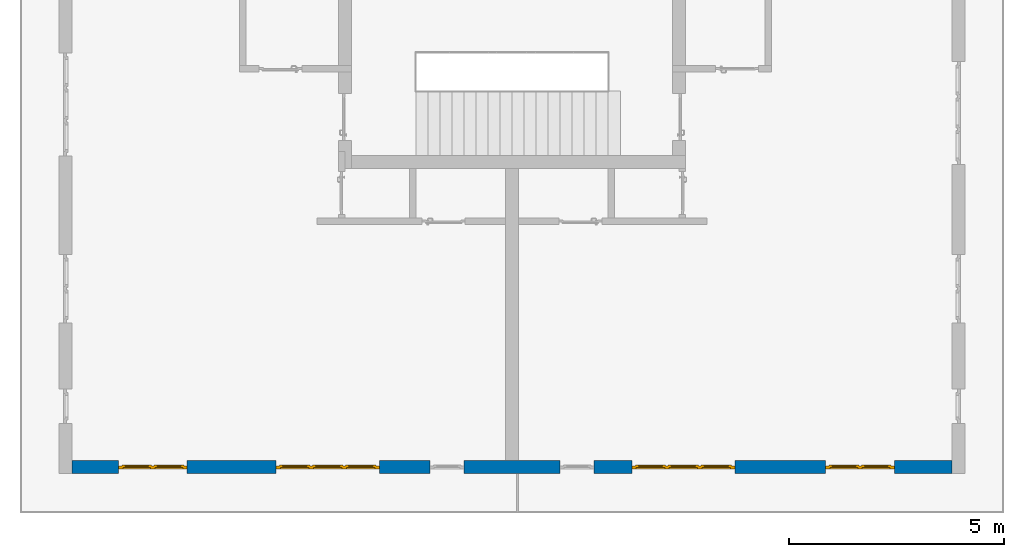
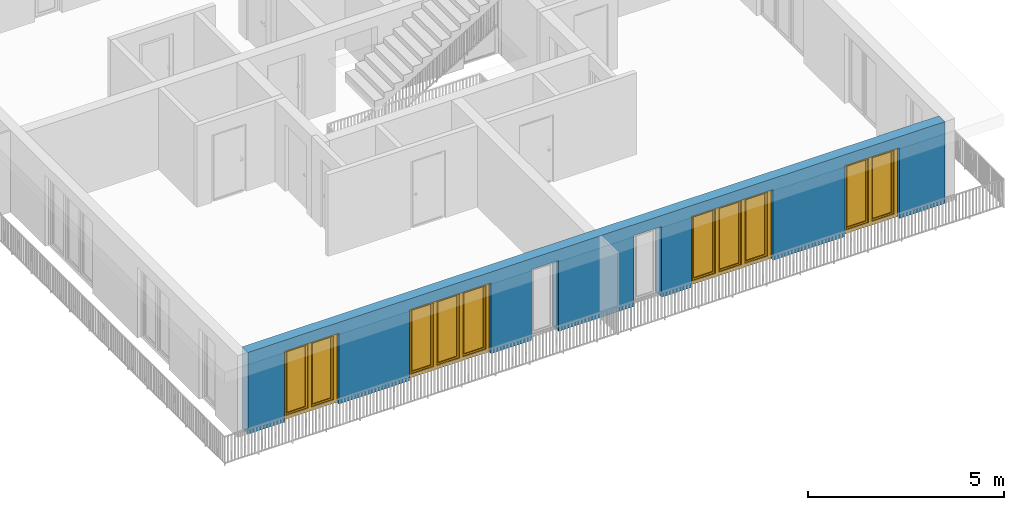
# One storey, part 5 of 48: 4 windows, 1 wall, 6 openings.
"""IFC4 building model written with IfcOpenShell, lengths in metres."""

import ifcopenshell
import ifcopenshell.guid

model = None  # the IFC model being written
_history = None  # IfcOwnerHistory: only IFC2X3 demands one
_inside = {}  # id of a spatial element -> (the spatial element, [elements in it])
_under = {}  # id of a project, library or spatial element -> (it, [spatial elements below it])
_declared = {}  # id of a project -> (the project, [libraries it declares])
_typed = {}  # id of a type object -> (the type object, [elements of that type])
_made_of = {}  # id of a material, layer set ... -> (it, [elements and type objects made of it])


def new_model(schema):
    """Start an empty IFC model of exactly this schema.

    Asked for "IFC4X3", IfcOpenShell would pick the latest addendum, in which some entities
    have other attributes; the version numbers below select the first issue.
    IFC2X3 requires an IfcOwnerHistory on every rooted entity: one is made here for all.
    """
    global model, _history
    if schema == "IFC4X3":
        model = ifcopenshell.file(schema_version=(4, 3, 0, 0))
    else:
        model = ifcopenshell.file(schema=schema)
    _inside.clear()
    _under.clear()
    _declared.clear()
    _typed.clear()
    _made_of.clear()
    _history = None
    if model.schema == "IFC2X3":
        org = make("IfcOrganization", Name="unknown")
        user = make(
            "IfcPersonAndOrganization",
            ThePerson=make("IfcPerson", FamilyName="unknown"),
            TheOrganization=org,
        )
        app = make(
            "IfcApplication",
            ApplicationDeveloper=org,
            Version="unknown",
            ApplicationFullName="unknown",
            ApplicationIdentifier="unknown",
        )
        _history = make(
            "IfcOwnerHistory",
            OwningUser=user,
            OwningApplication=app,
            ChangeAction="ADDED",
            CreationDate=0,
        )
    return model


def make(cls, **values):
    """One entity of the class cls with the attributes given. An attribute that is None is left unset."""
    return model.create_entity(
        cls, **{name: value for name, value in values.items() if value is not None}
    )


def entity(cls, *values):
    """Any entity or typed value of the class cls, its attributes in the order of the schema. None: left unset."""
    e = model.create_entity(cls)
    for i, value in enumerate(values):
        if value is not None:
            e[i] = value
    return e


def rooted(cls, **values):
    """An entity with a GlobalId (a new one), such as an element, a storey or a relation."""
    return make(cls, GlobalId=ifcopenshell.guid.new(), OwnerHistory=_history, **values)


def si_unit(unit_type, name, prefix=None):
    """IfcSIUnit, for example si_unit("LENGTHUNIT", "METRE", prefix="MILLI")."""
    return make("IfcSIUnit", UnitType=unit_type, Prefix=prefix, Name=name)


def converted_unit(unit_type, name, factor, base, dimensions=None, offset=None):
    """IfcConversionBasedUnit, such as the inch: factor (a typed value) times the base unit."""
    return make(
        "IfcConversionBasedUnit"
        if offset is None
        else "IfcConversionBasedUnitWithOffset",
        ConversionOffset=offset,
        Dimensions=None
        if dimensions is None
        else entity("IfcDimensionalExponents", *dimensions),
        UnitType=unit_type,
        Name=name,
        ConversionFactor=make(
            "IfcMeasureWithUnit", ValueComponent=factor, UnitComponent=base
        ),
    )


def derived_unit(unit_type, elements):
    """IfcDerivedUnit: a product of units, each with its exponent."""
    return make(
        "IfcDerivedUnit",
        Elements=[
            make("IfcDerivedUnitElement", Unit=unit, Exponent=power)
            for unit, power in elements
        ],
        UnitType=unit_type,
    )


def assignment(units):
    """IfcUnitAssignment: the units of a project."""
    return None if units is None else make("IfcUnitAssignment", Units=units)


def point(xyz):
    """IfcCartesianPoint."""
    return None if xyz is None else make("IfcCartesianPoint", Coordinates=xyz)


def direction(xyz):
    """IfcDirection."""
    return None if xyz is None else make("IfcDirection", DirectionRatios=xyz)


def frame(location, z_axis=None, x_axis=None):
    """IfcAxis2Placement3D, a coordinate frame: its origin and axes. An axis left out is left unset."""
    return make(
        "IfcAxis2Placement3D",
        Location=point(location),
        Axis=direction(z_axis),
        RefDirection=direction(x_axis),
    )


def origin_with_axes():
    """The frame at (0, 0, 0) with the z axis (0, 0, 1) and the x axis (1, 0, 0) written out."""
    return frame((0.0, 0.0, 0.0), z_axis=(0.0, 0.0, 1.0), x_axis=(1.0, 0.0, 0.0))


def place(relative_to, where):
    """IfcLocalPlacement: puts the frame where relative to a parent placement (None: the world)."""
    return make(
        "IfcLocalPlacement", PlacementRelTo=relative_to, RelativePlacement=where
    )


def context(
    kind, dimensions, precision=None, world=None, true_north=None, identifier=None
):
    """IfcGeometricRepresentationContext, for example the 3D "Model" context."""
    return make(
        "IfcGeometricRepresentationContext",
        ContextIdentifier=identifier,
        ContextType=kind,
        CoordinateSpaceDimension=dimensions,
        Precision=precision,
        WorldCoordinateSystem=world,
        TrueNorth=true_north,
    )


def subcontext(parent, identifier, kind, view, scale=None):
    """IfcGeometricRepresentationSubContext, for example "Body" below "Model"."""
    return make(
        "IfcGeometricRepresentationSubContext",
        ContextIdentifier=identifier,
        ContextType=kind,
        ParentContext=parent,
        TargetScale=scale,
        TargetView=view,
    )


def project(units=None, contexts=None):
    """IfcProject with its units and contexts."""
    return rooted(
        "IfcProject",
        Name="project",
        RepresentationContexts=contexts,
        UnitsInContext=assignment(units),
    )


def spatial(cls, under=None, at=None, **own):
    """A site, building, storey or space (cls), placed at a placement, below another one or the project."""
    s = rooted(cls, ObjectPlacement=at, **own)
    if under is not None:
        _under.setdefault(under.id(), (under, []))[1].append(s)
    return s


def point_list(points):
    """IfcCartesianPointList2D or 3D."""
    cls = (
        "IfcCartesianPointList2D" if len(points[0]) == 2 else "IfcCartesianPointList3D"
    )
    return make(cls, CoordList=points)


def polygons(points, faces, closed=None, point_numbers=None):
    """IfcPolygonalFaceSet: a face is its outer loop, then its inner loops; points numbered from 1."""
    made = []
    for loops in faces:
        if len(loops) == 1:
            made.append(make("IfcIndexedPolygonalFace", CoordIndex=loops[0]))
        else:
            made.append(
                make(
                    "IfcIndexedPolygonalFaceWithVoids",
                    CoordIndex=loops[0],
                    InnerCoordIndices=loops[1:],
                )
            )
    return make(
        "IfcPolygonalFaceSet",
        Coordinates=point_list(points),
        Closed=closed,
        Faces=made,
        PnIndex=point_numbers,
    )


def shape(context_of_items, identifier, shape_type, items):
    """IfcShapeRepresentation: the items that make up one representation, for example the "Body"."""
    return make(
        "IfcShapeRepresentation",
        ContextOfItems=context_of_items,
        RepresentationIdentifier=identifier,
        RepresentationType=shape_type,
        Items=items,
    )


def source(mapping_origin, context_of_items, identifier, shape_type, items):
    """IfcRepresentationMap: a shape defined once, which mapped items show again and again."""
    return make(
        "IfcRepresentationMap",
        MappingOrigin=mapping_origin,
        MappedRepresentation=shape(context_of_items, identifier, shape_type, items),
    )


def transform(
    local_origin,
    x_axis=None,
    y_axis=None,
    z_axis=None,
    scale=None,
    scale2=None,
    scale3=None,
    uniform=True,
):
    """IfcCartesianTransformationOperator3D, or its non-uniform kind. x_axis, y_axis, z_axis: its Axis1, 2, 3."""
    if uniform:
        return make(
            "IfcCartesianTransformationOperator3D",
            Axis1=direction(x_axis),
            Axis2=direction(y_axis),
            LocalOrigin=point(local_origin),
            Scale=scale,
            Axis3=direction(z_axis),
        )
    return make(
        "IfcCartesianTransformationOperator3DnonUniform",
        Axis1=direction(x_axis),
        Axis2=direction(y_axis),
        LocalOrigin=point(local_origin),
        Scale=scale,
        Axis3=direction(z_axis),
        Scale2=scale2,
        Scale3=scale3,
    )


def mapped(mapping_source, mapping_target):
    """IfcMappedItem: shows the shape of a source again, moved by a transform."""
    return make(
        "IfcMappedItem", MappingSource=mapping_source, MappingTarget=mapping_target
    )


def material(Name=None, Category=None):
    """IfcMaterial."""
    return make("IfcMaterial", Name=Name, Category=Category)


def made_of(thing, what):
    """Note that an element or type object is made of a material, layer set ...; save() writes the relation."""
    if what is not None:
        _made_of.setdefault(what.id(), (what, []))[1].append(thing)
    return thing


def type_object(cls, material=None, **own):
    """A type object (cls), such as IfcWallType, which elements share."""
    return made_of(rooted(cls, **own), material)


def element(
    cls,
    number,
    at=None,
    inside=None,
    cuts=None,
    type_object=None,
    material=None,
    context=None,
    identifier="Body",
    shape_type=None,
    held_by="IfcProductDefinitionShape",
    body=None,
    shapes=None,
    **own,
):
    """One element of the class cls, such as IfcWall. Its Tag is "e" and its number.

    at: its placement. inside: the storey or other place that contains it. cuts: it is an
    opening in that element (IfcRelVoidsElement). A single representation is given by context,
    identifier, shape_type and body (its items); several are given by shapes. held_by: the class
    of the entity that holds the representations. save() writes the other relations.
    """
    e = rooted(cls, Tag="e%d" % number, ObjectPlacement=at, **own)
    if body is not None:
        shapes = [shape(context, identifier, shape_type, body)]
    if shapes is not None:
        e.Representation = make(held_by, Representations=shapes)
    if inside is not None:
        _inside.setdefault(inside.id(), (inside, []))[1].append(e)
    if cuts is not None:
        rooted(
            "IfcRelVoidsElement", RelatingBuildingElement=cuts, RelatedOpeningElement=e
        )
    if type_object is not None:
        _typed.setdefault(type_object.id(), (type_object, []))[1].append(e)
    return made_of(e, material)


def fill(opening, filler):
    """IfcRelFillsElement: the door or window that sits in an opening."""
    return rooted(
        "IfcRelFillsElement",
        RelatingOpeningElement=opening,
        RelatedBuildingElement=filler,
    )


def aggregate(whole, parts):
    """IfcRelAggregates: a whole, such as a stair, and the parts it consists of."""
    return rooted("IfcRelAggregates", RelatingObject=whole, RelatedObjects=parts)


def save(model, path):
    """Write the relations noted so far, then the file.

    IfcRelAggregates (storeys below a building ...), IfcRelContainedInSpatialStructure (elements
    in a storey), IfcRelDefinesByType, IfcRelAssociatesMaterial and IfcRelDeclares: one each for
    every whole, place, type object, material and project.
    """
    for whole, parts in _under.values():
        aggregate(whole, parts)
    for where, things in _inside.values():
        rooted(
            "IfcRelContainedInSpatialStructure",
            RelatedElements=things,
            RelatingStructure=where,
        )
    for kind, things in _typed.values():
        rooted("IfcRelDefinesByType", RelatedObjects=things, RelatingType=kind)
    for what, things in _made_of.values():
        rooted("IfcRelAssociatesMaterial", RelatedObjects=things, RelatingMaterial=what)
    for by, libraries in _declared.values():
        rooted("IfcRelDeclares", RelatingContext=by, RelatedDefinitions=libraries)
    model.write(path)


model = new_model("IFC4")

# Units and contexts
model_context = context("Model", 3, precision=1e-05, world=origin_with_axes(), true_north=direction((0.0, 1.0)))
body_context = subcontext(model_context, "Body", "Model", "MODEL_VIEW")
ifc_project = project(units=[si_unit("LENGTHUNIT", "METRE"), si_unit("AREAUNIT", "SQUARE_METRE"), si_unit("VOLUMEUNIT", "CUBIC_METRE"), converted_unit("PLANEANGLEUNIT", "DEGREE", entity("IfcPlaneAngleMeasure", 0.0174532925199), si_unit("PLANEANGLEUNIT", "RADIAN"), dimensions=[0, 0, 0, 0, 0, 0, 0]), converted_unit("TIMEUNIT", "Year", entity("IfcTimeMeasure", 31556926.0), si_unit("TIMEUNIT", "SECOND"), dimensions=[0, 0, 1, 0, 0, 0, 0]), si_unit("MASSUNIT", "GRAM", prefix="KILO"), si_unit("THERMODYNAMICTEMPERATUREUNIT", "DEGREE_CELSIUS"), si_unit("LUMINOUSINTENSITYUNIT", "LUMEN"), si_unit("ENERGYUNIT", "JOULE", prefix="MEGA"), derived_unit("THERMALCONDUCTANCEUNIT", [(si_unit("POWERUNIT", "WATT"), 1), (si_unit("LENGTHUNIT", "METRE"), -1), (si_unit("THERMODYNAMICTEMPERATUREUNIT", "KELVIN"), -1)]), derived_unit("SPECIFICHEATCAPACITYUNIT", [(si_unit("ENERGYUNIT", "JOULE"), 1), (si_unit("MASSUNIT", "GRAM", prefix="KILO"), -1), (si_unit("THERMODYNAMICTEMPERATUREUNIT", "KELVIN"), -1)]), derived_unit("MASSDENSITYUNIT", [(si_unit("MASSUNIT", "GRAM", prefix="KILO"), 1), (si_unit("VOLUMEUNIT", "CUBIC_METRE"), -1)])], contexts=[model_context])

# Site, building, storey
site_placement = place(None, origin_with_axes())
site = spatial("IfcSite", under=ifc_project, at=site_placement, CompositionType="ELEMENT")
building_placement = place(site_placement, origin_with_axes())
building = spatial("IfcBuilding", under=site, at=building_placement, CompositionType="ELEMENT")
storey_placement = place(building_placement, frame((0.0, 0.0, 3.4), z_axis=(0.0, 0.0, 1.0), x_axis=(1.0, 0.0, 0.0)))
storey = spatial("IfcBuildingStorey", under=building, at=storey_placement, Name="1. Geschoss", CompositionType="ELEMENT", Elevation=3.4)

# Wall, openings, windows
ifc_material = material()
wall_type = type_object("IfcWallType", Name="300", PredefinedType="NOTDEFINED")
wall_placement = place(storey_placement, frame((9.3378006196, -9.92881223104, 0.0), z_axis=(0.0, 0.0, 1.0), x_axis=(-1.0, 0.0, 0.0)))
wall = element("IfcWall", 1, at=wall_placement, inside=storey, type_object=wall_type, material=ifc_material, Name="Wand-001", PredefinedType="NOTDEFINED", context=body_context, shape_type="Tessellation", body=[
    polygons([(12.4515538751, -0.3, 2.2), (12.4515538751, -0.3, 0.0), (13.63, -0.3, 0.0), (13.63, -0.3, 2.2), (16.03, -0.3, 2.2), (16.03, -0.3, 0.0), (18.0998837323, -0.3, 0.0), (18.0998837323, -0.3, 2.2), (19.6998837323, -0.3, 2.2), (19.6998837323, -0.3, 0.0), (20.78, -0.3, 0.0), (20.78, -0.3, 2.54), (0.3, -0.3, 2.54), (0.3, -0.3, 0.0), (1.6378225413, -0.3, 0.0), (1.6378225413, -0.3, 2.2), (3.2378225413, -0.3, 2.2), (3.2378225413, -0.3, 0.0), (5.35, -0.3, 0.0), (5.35, -0.3, 2.2), (7.75, -0.3, 2.2), (7.75, -0.3, 0.0), (8.62617854928, -0.3, 0.0), (8.62617854928, -0.3, 2.2), (9.42617854928, -0.3, 2.2), (9.42617854928, -0.3, 0.0), (11.6515538751, -0.3, 0.0), (11.6515538751, -0.3, 2.2), (12.4515538751, -0.1, 0.0), (12.4515538751, 0.0, 2.2), (12.4515538751, 0.0, 0.0), (13.63, 0.0, 0.0), (13.63, 0.0, 2.2), (16.03, 0.0, 2.2), (16.03, 0.0, 0.0), (18.0998837323, 0.0, 0.0), (18.0998837323, 0.0, 2.2), (19.6998837323, 0.0, 2.2), (19.6998837323, 0.0, 0.0), (20.78, 0.0, 0.0), (20.78, 0.0, 2.54), (0.3, 0.0, 2.54), (0.3, 0.0, 0.0), (1.6378225413, 0.0, 0.0), (1.6378225413, 0.0, 2.2), (3.2378225413, 0.0, 2.2), (3.2378225413, 0.0, 0.0), (5.35, 0.0, 0.0), (5.35, 0.0, 2.2), (7.75, 0.0, 2.2), (7.75, 0.0, 0.0), (8.62617854928, 0.0, 0.0), (8.62617854928, 0.0, 2.2), (9.42617854928, 0.0, 2.2), (9.42617854928, 0.0, 0.0), (11.6515538751, -0.1, 0.0), (11.6515538751, 0.0, 0.0), (11.6515538751, 0.0, 2.2)], [[[1, 2, 3, 4, 5, 6, 7, 8, 9, 10, 11, 12, 13, 14, 15, 16, 17, 18, 19, 20, 21, 22, 23, 24, 25, 26, 27, 28]], [[29, 2, 1, 30, 31]], [[2, 29, 31, 32, 3]], [[32, 33, 4, 3]], [[33, 34, 5, 4]], [[34, 35, 6, 5]], [[36, 7, 6, 35]], [[36, 37, 8, 7]], [[37, 38, 9, 8]], [[38, 39, 10, 9]], [[40, 11, 10, 39]], [[40, 41, 12, 11]], [[41, 42, 13, 12]], [[14, 13, 42, 43]], [[15, 14, 43, 44]], [[16, 15, 44, 45]], [[17, 16, 45, 46]], [[18, 17, 46, 47]], [[19, 18, 47, 48]], [[20, 19, 48, 49]], [[21, 20, 49, 50]], [[22, 21, 50, 51]], [[51, 52, 23, 22]], [[52, 53, 24, 23]], [[53, 54, 25, 24]], [[54, 55, 26, 25]], [[56, 27, 26, 55, 57]], [[28, 27, 56, 57, 58]], [[1, 28, 58, 30]], [[32, 31, 30, 58, 57, 55, 54, 53, 52, 51, 50, 49, 48, 47, 46, 45, 44, 43, 42, 41, 40, 39, 38, 37, 36, 35, 34, 33]]], closed=True),
])
opening_1_placement = place(wall_placement, frame((18.8998837323, 0.0, 0.0), z_axis=(0.0, 0.0, 1.0), x_axis=(1.0, 0.0, 0.0)))
opening_1 = element("IfcOpeningElement", 2, at=opening_1_placement, cuts=wall, Name="Fenster-001", context=body_context, identifier="Reference", shape_type="Tessellation", body=[
    polygons([(-0.8, -0.1, 0.0), (-0.8, -0.1, 2.2), (-0.8, 0.001, 2.2), (-0.8, 0.001, 0.0), (-0.8, -0.301, 0.0), (-0.8, -0.301, 2.2), (0.8, -0.1, 2.2), (0.8, 0.001, 2.2), (0.8, -0.301, 2.2), (0.8, 0.001, 0.0), (0.8, -0.1, 0.0), (0.8, -0.301, 0.0)], [[[1, 2, 3, 4]], [[2, 1, 5, 6]], [[7, 8, 3, 2, 6, 9]], [[8, 10, 4, 3]], [[1, 4, 10, 11, 12, 5]], [[6, 5, 12, 9]], [[7, 11, 10, 8]], [[11, 7, 9, 12]]], closed=True),
])
opening_2_placement = place(wall_placement, frame((2.4378225413, 0.0, 0.0), z_axis=(0.0, 0.0, 1.0), x_axis=(1.0, 0.0, 0.0)))
opening_2 = element("IfcOpeningElement", 3, at=opening_2_placement, cuts=wall, Name="Fenster-002", context=body_context, identifier="Reference", shape_type="Tessellation", body=[
    polygons([(-0.8, -0.1, 0.0), (-0.8, -0.1, 2.2), (-0.8, 0.000999999999999, 2.2), (-0.8, 0.000999999999999, 0.0), (-0.8, -0.301, 0.0), (-0.8, -0.301, 2.2), (0.8, -0.1, 2.2), (0.8, 0.000999999999999, 2.2), (0.8, -0.301, 2.2), (0.8, 0.000999999999999, 0.0), (0.8, -0.1, 0.0), (0.8, -0.301, 0.0)], [[[1, 2, 3, 4]], [[2, 1, 5, 6]], [[7, 8, 3, 2, 6, 9]], [[8, 10, 4, 3]], [[1, 4, 10, 11, 12, 5]], [[6, 5, 12, 9]], [[7, 11, 10, 8]], [[11, 7, 9, 12]]], closed=True),
])
opening_3_placement = place(wall_placement, frame((14.83, 0.0, 0.0), z_axis=(0.0, 0.0, 1.0), x_axis=(1.0, 0.0, 0.0)))
opening_3 = element("IfcOpeningElement", 4, at=opening_3_placement, cuts=wall, Name="Fenster-002", context=body_context, identifier="Reference", shape_type="Tessellation", body=[
    polygons([(-1.2, -0.1, 0.0), (-1.2, -0.1, 2.2), (-1.2, 0.001, 2.2), (-1.2, 0.001, 0.0), (-1.2, -0.301, 0.0), (-1.2, -0.301, 2.2), (1.2, -0.1, 2.2), (1.2, 0.001, 2.2), (1.2, -0.301, 2.2), (1.2, 0.001, 0.0), (1.2, -0.1, 0.0), (1.2, -0.301, 0.0)], [[[1, 2, 3, 4]], [[2, 1, 5, 6]], [[7, 8, 3, 2, 6, 9]], [[8, 10, 4, 3]], [[1, 4, 10, 11, 12, 5]], [[6, 5, 12, 9]], [[7, 11, 10, 8]], [[11, 7, 9, 12]]], closed=True),
])
opening_4_placement = place(wall_placement, frame((6.55, 0.0, 0.0), z_axis=(0.0, 0.0, 1.0), x_axis=(1.0, 0.0, 0.0)))
opening_4 = element("IfcOpeningElement", 5, at=opening_4_placement, cuts=wall, Name="Fenster-003", context=body_context, identifier="Reference", shape_type="Tessellation", body=[
    polygons([(-1.2, -0.1, 0.0), (-1.2, -0.1, 2.2), (-1.2, 0.000999999999999, 2.2), (-1.2, 0.000999999999999, 0.0), (-1.2, -0.301, 0.0), (-1.2, -0.301, 2.2), (1.2, -0.1, 2.2), (1.2, 0.001, 2.2), (1.2, -0.301, 2.2), (1.2, 0.001, 0.0), (1.2, -0.1, 0.0), (1.2, -0.301, 0.0)], [[[1, 2, 3, 4]], [[2, 1, 5, 6]], [[7, 8, 3, 2, 6, 9]], [[8, 10, 4, 3]], [[1, 4, 10, 11, 12, 5]], [[6, 5, 12, 9]], [[7, 11, 10, 8]], [[11, 7, 9, 12]]], closed=True),
])
opening_5_placement = place(wall_placement, frame((9.02617854928, 0.0, 0.0), z_axis=(0.0, 0.0, 1.0), x_axis=(1.0, 0.0, 0.0)))
element("IfcOpeningElement", 6, at=opening_5_placement, cuts=wall, Name="Fenster-003", context=body_context, identifier="Reference", shape_type="Tessellation", body=[
    polygons([(-0.4, -0.1, 0.0), (-0.4, -0.1, 2.2), (-0.4, 0.001, 2.2), (-0.4, 0.001, 0.0), (-0.4, -0.301, 0.0), (-0.4, -0.301, 2.2), (0.4, -0.1, 2.2), (0.4, 0.001, 2.2), (0.4, -0.301, 2.2), (0.4, 0.001, 0.0), (0.4, -0.1, 0.0), (0.4, -0.301, 0.0)], [[[1, 2, 3, 4]], [[2, 1, 5, 6]], [[7, 8, 3, 2, 6, 9]], [[8, 10, 4, 3]], [[1, 4, 10, 11, 12, 5]], [[6, 5, 12, 9]], [[7, 11, 10, 8]], [[11, 7, 9, 12]]], closed=True),
])
opening_6_placement = place(wall_placement, frame((12.0515538751, 0.0, 0.0), z_axis=(0.0, 0.0, 1.0), x_axis=(1.0, 0.0, 0.0)))
element("IfcOpeningElement", 7, at=opening_6_placement, cuts=wall, Name="Fenster-003", context=body_context, identifier="Reference", shape_type="Tessellation", body=[
    polygons([(-0.4, -0.1, 0.0), (-0.4, -0.1, 2.2), (-0.4, 0.001, 2.2), (-0.4, 0.001, 0.0), (-0.4, -0.301, 0.0), (-0.4, -0.301, 2.2), (0.4, -0.1, 2.2), (0.4, 0.001, 2.2), (0.4, -0.301, 2.2), (0.4, 0.001, 0.0), (0.4, -0.1, 0.0), (0.4, -0.301, 0.0)], [[[1, 2, 3, 4]], [[2, 1, 5, 6]], [[7, 8, 3, 2, 6, 9]], [[8, 10, 4, 3]], [[1, 4, 10, 11, 12, 5]], [[6, 5, 12, 9]], [[7, 11, 10, 8]], [[11, 7, 9, 12]]], closed=True),
])
window_type_1 = type_object("IfcWindowType", Name="2-1+1 26", PartitioningType="DOUBLE_PANEL_VERTICAL", PredefinedType="WINDOW")
shared_shape_1 = source(origin_with_axes(), body_context, "Body", "Tessellation", [
    polygons([(-0.8, -0.07, 0.0), (-0.8, 0.0, 0.0), (-0.7, 0.0, 0.1), (-0.7, -0.07, 0.1), (-0.8, -0.07, 2.2), (-0.8, 0.0, 2.2), (-0.7, 0.0, 2.1), (-0.7, -0.07, 2.1)], [[[1, 2, 3, 4]], [[5, 6, 2, 1]], [[2, 6, 7, 3]], [[4, 3, 7, 8]], [[1, 4, 8, 5]], [[8, 7, 6, 5]]], closed=True),
    polygons([(0.8, -0.07, 0.0), (0.8, 0.0, 0.0), (0.8, 0.0, 2.2), (0.8, -0.07, 2.2), (0.7, -0.07, 0.1), (0.7, 0.0, 0.1), (0.7, 0.0, 2.1), (0.7, -0.07, 2.1)], [[[1, 2, 3, 4]], [[5, 6, 2, 1]], [[2, 6, 7, 3]], [[4, 3, 7, 8]], [[1, 4, 8, 5]], [[8, 7, 6, 5]]], closed=True),
    polygons([(-0.8, -0.07, 0.0), (-0.8, 0.0, 0.0), (0.8, 0.0, 0.0), (0.8, -0.07, 0.0), (-0.7, -0.07, 0.1), (-0.7, 0.0, 0.1), (-0.05, 0.0, 0.1), (0.05, 0.0, 0.1), (0.7, 0.0, 0.1), (0.7, -0.07, 0.1), (0.05, -0.07, 0.1), (-0.05, -0.07, 0.1)], [[[1, 2, 3, 4]], [[5, 6, 2, 1]], [[2, 6, 7, 8, 9, 3]], [[4, 3, 9, 10]], [[1, 4, 10, 11, 12, 5]], [[12, 7, 6, 5]], [[11, 8, 7, 12]], [[10, 9, 8, 11]]], closed=True),
    polygons([(-0.8, -0.07, 2.2), (-0.8, 0.0, 2.2), (-0.7, 0.0, 2.1), (-0.7, -0.07, 2.1), (0.8, -0.07, 2.2), (0.8, 0.0, 2.2), (0.7, 0.0, 2.1), (0.05, 0.0, 2.1), (-0.05, 0.0, 2.1), (-0.05, -0.07, 2.1), (0.05, -0.07, 2.1), (0.7, -0.07, 2.1)], [[[1, 2, 3, 4]], [[5, 6, 2, 1]], [[2, 6, 7, 8, 9, 3]], [[4, 3, 9, 10]], [[1, 4, 10, 11, 12, 5]], [[12, 7, 6, 5]], [[11, 8, 7, 12]], [[10, 9, 8, 11]]], closed=True),
    polygons([(-0.05, -0.07, 0.1), (-0.05, 0.0, 0.1), (0.05, 0.0, 0.1), (0.05, -0.07, 0.1), (-0.05, -0.07, 2.1), (-0.05, 0.0, 2.1), (0.05, 0.0, 2.1), (0.05, -0.07, 2.1)], [[[1, 2, 3, 4]], [[5, 6, 2, 1]], [[2, 6, 7, 3]], [[4, 3, 7, 8]], [[1, 4, 8, 5]], [[8, 7, 6, 5]]], closed=True),
    polygons([(-0.72, 0.0, 0.08), (-0.72, 0.03, 0.08), (-0.65, 0.03, 0.15), (-0.65, 0.0, 0.15), (-0.72, 0.0, 2.12), (-0.72, 0.03, 2.12), (-0.65, 0.03, 2.05), (-0.65, 0.0, 2.05)], [[[1, 2, 3, 4]], [[5, 6, 2, 1]], [[2, 6, 7, 3]], [[4, 3, 7, 8]], [[1, 4, 8, 5]], [[8, 7, 6, 5]]], closed=True),
    polygons([(-0.03, 0.0, 0.08), (-0.1, 0.0, 0.15), (-0.1, 0.03, 0.15), (-0.03, 0.03, 0.08), (-0.03, 0.0, 2.12), (-0.1, 0.0, 2.05), (-0.1, 0.03, 2.05), (-0.03, 0.03, 2.12)], [[[1, 2, 3, 4]], [[1, 5, 6, 2]], [[2, 6, 7, 3]], [[4, 3, 7, 8]], [[5, 1, 4, 8]], [[6, 5, 8, 7]]], closed=True),
    polygons([(-0.72, 0.0, 0.08), (-0.72, 0.03, 0.08), (-0.03, 0.03, 0.08), (-0.03, 0.0, 0.08), (-0.65, 0.0, 0.15), (-0.65, 0.03, 0.15), (-0.1, 0.03, 0.15), (-0.1, 0.0, 0.15)], [[[1, 2, 3, 4]], [[5, 6, 2, 1]], [[2, 6, 7, 3]], [[4, 3, 7, 8]], [[1, 4, 8, 5]], [[8, 7, 6, 5]]], closed=True),
    polygons([(-0.72, 0.0, 2.12), (-0.03, 0.0, 2.12), (-0.03, 0.03, 2.12), (-0.72, 0.03, 2.12), (-0.65, 0.0, 2.05), (-0.1, 0.0, 2.05), (-0.1, 0.03, 2.05), (-0.65, 0.03, 2.05)], [[[1, 2, 3, 4]], [[1, 5, 6, 2]], [[2, 6, 7, 3]], [[4, 3, 7, 8]], [[5, 1, 4, 8]], [[6, 5, 8, 7]]], closed=True),
    polygons([(-0.7, -0.03, 0.1), (-0.7, 0.0, 0.1), (-0.65, 0.0, 0.15), (-0.65, -0.03, 0.15), (-0.7, -0.03, 2.1), (-0.7, 0.0, 2.1), (-0.65, 0.0, 2.05), (-0.65, -0.03, 2.05)], [[[1, 2, 3, 4]], [[5, 6, 2, 1]], [[2, 6, 7, 3]], [[4, 3, 7, 8]], [[1, 4, 8, 5]], [[8, 7, 6, 5]]], closed=True),
    polygons([(-0.05, -0.03, 0.1), (-0.1, -0.03, 0.15), (-0.1, 0.0, 0.15), (-0.05, 0.0, 0.1), (-0.05, -0.03, 2.1), (-0.1, -0.03, 2.05), (-0.1, 0.0, 2.05), (-0.05, 0.0, 2.1)], [[[1, 2, 3, 4]], [[1, 5, 6, 2]], [[2, 6, 7, 3]], [[4, 3, 7, 8]], [[5, 1, 4, 8]], [[6, 5, 8, 7]]], closed=True),
    polygons([(-0.7, -0.03, 0.1), (-0.7, 0.0, 0.1), (-0.05, 0.0, 0.1), (-0.05, -0.03, 0.1), (-0.65, -0.03, 0.15), (-0.65, 0.0, 0.15), (-0.1, 0.0, 0.15), (-0.1, -0.03, 0.15)], [[[1, 2, 3, 4]], [[5, 6, 2, 1]], [[2, 6, 7, 3]], [[4, 3, 7, 8]], [[1, 4, 8, 5]], [[8, 7, 6, 5]]], closed=True),
    polygons([(-0.7, -0.03, 2.1), (-0.05, -0.03, 2.1), (-0.05, 0.0, 2.1), (-0.7, 0.0, 2.1), (-0.65, -0.03, 2.05), (-0.1, -0.03, 2.05), (-0.1, 0.0, 2.05), (-0.65, 0.0, 2.05)], [[[1, 2, 3, 4]], [[1, 5, 6, 2]], [[2, 6, 7, 3]], [[4, 3, 7, 8]], [[5, 1, 4, 8]], [[6, 5, 8, 7]]], closed=True),
    polygons([(-0.65, -0.005, 0.15), (-0.65, 0.005, 0.15), (-0.1, 0.005, 0.15), (-0.1, -0.005, 0.15), (-0.65, -0.005, 2.05), (-0.65, 0.005, 2.05), (-0.1, 0.005, 2.05), (-0.1, -0.005, 2.05)], [[[1, 2, 3, 4]], [[5, 6, 2, 1]], [[2, 6, 7, 3]], [[4, 3, 7, 8]], [[1, 4, 8, 5]], [[8, 7, 6, 5]]], closed=True),
    polygons([(0.03, 0.0, 0.08), (0.03, 0.03, 0.08), (0.1, 0.03, 0.15), (0.1, 0.0, 0.15), (0.03, 0.0, 2.12), (0.03, 0.03, 2.12), (0.1, 0.03, 2.05), (0.1, 0.0, 2.05)], [[[1, 2, 3, 4]], [[5, 6, 2, 1]], [[2, 6, 7, 3]], [[4, 3, 7, 8]], [[1, 4, 8, 5]], [[8, 7, 6, 5]]], closed=True),
    polygons([(0.72, 0.0, 0.08), (0.65, 0.0, 0.15), (0.65, 0.03, 0.15), (0.72, 0.03, 0.08), (0.72, 0.0, 2.12), (0.65, 0.0, 2.05), (0.65, 0.03, 2.05), (0.72, 0.03, 2.12)], [[[1, 2, 3, 4]], [[1, 5, 6, 2]], [[2, 6, 7, 3]], [[4, 3, 7, 8]], [[5, 1, 4, 8]], [[6, 5, 8, 7]]], closed=True),
    polygons([(0.03, 0.0, 0.08), (0.03, 0.03, 0.08), (0.72, 0.03, 0.08), (0.72, 0.0, 0.08), (0.1, 0.0, 0.15), (0.1, 0.03, 0.15), (0.65, 0.03, 0.15), (0.65, 0.0, 0.15)], [[[1, 2, 3, 4]], [[5, 6, 2, 1]], [[2, 6, 7, 3]], [[4, 3, 7, 8]], [[1, 4, 8, 5]], [[8, 7, 6, 5]]], closed=True),
    polygons([(0.03, 0.0, 2.12), (0.72, 0.0, 2.12), (0.72, 0.03, 2.12), (0.03, 0.03, 2.12), (0.1, 0.0, 2.05), (0.65, 0.0, 2.05), (0.65, 0.03, 2.05), (0.1, 0.03, 2.05)], [[[1, 2, 3, 4]], [[1, 5, 6, 2]], [[2, 6, 7, 3]], [[4, 3, 7, 8]], [[5, 1, 4, 8]], [[6, 5, 8, 7]]], closed=True),
    polygons([(0.05, -0.03, 0.1), (0.05, 0.0, 0.1), (0.1, 0.0, 0.15), (0.1, -0.03, 0.15), (0.05, -0.03, 2.1), (0.05, 0.0, 2.1), (0.1, 0.0, 2.05), (0.1, -0.03, 2.05)], [[[1, 2, 3, 4]], [[5, 6, 2, 1]], [[2, 6, 7, 3]], [[4, 3, 7, 8]], [[1, 4, 8, 5]], [[8, 7, 6, 5]]], closed=True),
    polygons([(0.7, -0.03, 0.1), (0.65, -0.03, 0.15), (0.65, 0.0, 0.15), (0.7, 0.0, 0.1), (0.7, -0.03, 2.1), (0.65, -0.03, 2.05), (0.65, 0.0, 2.05), (0.7, 0.0, 2.1)], [[[1, 2, 3, 4]], [[1, 5, 6, 2]], [[2, 6, 7, 3]], [[4, 3, 7, 8]], [[5, 1, 4, 8]], [[6, 5, 8, 7]]], closed=True),
    polygons([(0.05, -0.03, 0.1), (0.05, 0.0, 0.1), (0.7, 0.0, 0.1), (0.7, -0.03, 0.1), (0.1, -0.03, 0.15), (0.1, 0.0, 0.15), (0.65, 0.0, 0.15), (0.65, -0.03, 0.15)], [[[1, 2, 3, 4]], [[5, 6, 2, 1]], [[2, 6, 7, 3]], [[4, 3, 7, 8]], [[1, 4, 8, 5]], [[8, 7, 6, 5]]], closed=True),
    polygons([(0.05, -0.03, 2.1), (0.7, -0.03, 2.1), (0.7, 0.0, 2.1), (0.05, 0.0, 2.1), (0.1, -0.03, 2.05), (0.65, -0.03, 2.05), (0.65, 0.0, 2.05), (0.1, 0.0, 2.05)], [[[1, 2, 3, 4]], [[1, 5, 6, 2]], [[2, 6, 7, 3]], [[4, 3, 7, 8]], [[5, 1, 4, 8]], [[6, 5, 8, 7]]], closed=True),
    polygons([(0.1, -0.005, 0.15), (0.1, 0.005, 0.15), (0.65, 0.005, 0.15), (0.65, -0.005, 0.15), (0.1, -0.005, 2.05), (0.1, 0.005, 2.05), (0.65, 0.005, 2.05), (0.65, -0.005, 2.05)], [[[1, 2, 3, 4]], [[5, 6, 2, 1]], [[2, 6, 7, 3]], [[4, 3, 7, 8]], [[1, 4, 8, 5]], [[8, 7, 6, 5]]], closed=True),
])
window_1_placement = place(opening_1_placement, frame((0.8, 0.0, 0.0), z_axis=(0.0, 0.0, 1.0), x_axis=(-1.0, 0.0, 0.0)))
window_1 = element("IfcWindow", 8, at=window_1_placement, inside=storey, type_object=window_type_1, Name="Fenster-001", OverallHeight=2.2, OverallWidth=1.6, PredefinedType="WINDOW", context=body_context, shape_type="MappedRepresentation", body=[
    mapped(shared_shape_1, transform((0.8, 0.17, 0.0))),
])
fill(opening_1, window_1)
window_2_placement = place(opening_2_placement, frame((0.8, 0.0, 0.0), z_axis=(0.0, 0.0, 1.0), x_axis=(-1.0, 0.0, 0.0)))
window_2 = element("IfcWindow", 9, at=window_2_placement, inside=storey, type_object=window_type_1, Name="Fenster-002", OverallHeight=2.2, OverallWidth=1.6, PredefinedType="WINDOW", context=body_context, shape_type="MappedRepresentation", body=[
    mapped(shared_shape_1, transform((0.8, 0.17, 0.0))),
])
fill(opening_2, window_2)
window_type_2 = type_object("IfcWindowType", Name="3-1+1+1 26", PartitioningType="TRIPLE_PANEL_VERTICAL", PredefinedType="WINDOW")
shared_shape_2 = source(origin_with_axes(), body_context, "Body", "Tessellation", [
    polygons([(-1.2, -0.07, 0.0), (-1.2, 0.0, 0.0), (-1.1, 0.0, 0.1), (-1.1, -0.07, 0.1), (-1.2, -0.07, 2.2), (-1.2, 0.0, 2.2), (-1.1, 0.0, 2.1), (-1.1, -0.07, 2.1)], [[[1, 2, 3, 4]], [[5, 6, 2, 1]], [[2, 6, 7, 3]], [[4, 3, 7, 8]], [[1, 4, 8, 5]], [[8, 7, 6, 5]]], closed=True),
    polygons([(1.2, -0.07, 0.0), (1.2, 0.0, 0.0), (1.2, 0.0, 2.2), (1.2, -0.07, 2.2), (1.1, -0.07, 0.1), (1.1, 0.0, 0.1), (1.1, 0.0, 2.1), (1.1, -0.07, 2.1)], [[[1, 2, 3, 4]], [[5, 6, 2, 1]], [[2, 6, 7, 3]], [[4, 3, 7, 8]], [[1, 4, 8, 5]], [[8, 7, 6, 5]]], closed=True),
    polygons([(-1.2, -0.07, 0.0), (-1.2, 0.0, 0.0), (1.2, 0.0, 0.0), (1.2, -0.07, 0.0), (-1.1, -0.07, 0.1), (-1.1, 0.0, 0.1), (-0.433333333333, 0.0, 0.1), (-0.333333333333, 0.0, 0.1), (0.333333333333, 0.0, 0.1), (0.433333333333, 0.0, 0.1), (1.1, 0.0, 0.1), (1.1, -0.07, 0.1), (0.433333333333, -0.07, 0.1), (0.333333333333, -0.07, 0.1), (-0.333333333333, -0.07, 0.1), (-0.433333333333, -0.07, 0.1)], [[[1, 2, 3, 4]], [[5, 6, 2, 1]], [[2, 6, 7, 8, 9, 10, 11, 3]], [[4, 3, 11, 12]], [[1, 4, 12, 13, 14, 15, 16, 5]], [[16, 7, 6, 5]], [[15, 8, 7, 16]], [[14, 9, 8, 15]], [[13, 10, 9, 14]], [[12, 11, 10, 13]]], closed=True),
    polygons([(-1.2, -0.07, 2.2), (-1.2, 0.0, 2.2), (-1.1, 0.0, 2.1), (-1.1, -0.07, 2.1), (1.2, -0.07, 2.2), (1.2, 0.0, 2.2), (1.1, 0.0, 2.1), (0.433333333333, 0.0, 2.1), (0.333333333333, 0.0, 2.1), (-0.333333333333, 0.0, 2.1), (-0.433333333333, 0.0, 2.1), (-0.433333333333, -0.07, 2.1), (-0.333333333333, -0.07, 2.1), (0.333333333333, -0.07, 2.1), (0.433333333333, -0.07, 2.1), (1.1, -0.07, 2.1)], [[[1, 2, 3, 4]], [[5, 6, 2, 1]], [[2, 6, 7, 8, 9, 10, 11, 3]], [[4, 3, 11, 12]], [[1, 4, 12, 13, 14, 15, 16, 5]], [[16, 7, 6, 5]], [[15, 8, 7, 16]], [[14, 9, 8, 15]], [[13, 10, 9, 14]], [[12, 11, 10, 13]]], closed=True),
    polygons([(0.333333333333, -0.07, 0.1), (0.333333333333, 0.0, 0.1), (0.433333333333, 0.0, 0.1), (0.433333333333, -0.07, 0.1), (0.333333333333, -0.07, 2.1), (0.333333333333, 0.0, 2.1), (0.433333333333, 0.0, 2.1), (0.433333333333, -0.07, 2.1)], [[[1, 2, 3, 4]], [[5, 6, 2, 1]], [[2, 6, 7, 3]], [[4, 3, 7, 8]], [[1, 4, 8, 5]], [[8, 7, 6, 5]]], closed=True),
    polygons([(-0.433333333333, -0.07, 0.1), (-0.433333333333, 0.0, 0.1), (-0.333333333333, 0.0, 0.1), (-0.333333333333, -0.07, 0.1), (-0.433333333333, -0.07, 2.1), (-0.433333333333, 0.0, 2.1), (-0.333333333333, 0.0, 2.1), (-0.333333333333, -0.07, 2.1)], [[[1, 2, 3, 4]], [[5, 6, 2, 1]], [[2, 6, 7, 3]], [[4, 3, 7, 8]], [[1, 4, 8, 5]], [[8, 7, 6, 5]]], closed=True),
    polygons([(-1.12, 0.0, 0.08), (-1.12, 0.03, 0.08), (-1.05, 0.03, 0.15), (-1.05, 0.0, 0.15), (-1.12, 0.0, 2.12), (-1.12, 0.03, 2.12), (-1.05, 0.03, 2.05), (-1.05, 0.0, 2.05)], [[[1, 2, 3, 4]], [[5, 6, 2, 1]], [[2, 6, 7, 3]], [[4, 3, 7, 8]], [[1, 4, 8, 5]], [[8, 7, 6, 5]]], closed=True),
    polygons([(-0.413333333333, 0.0, 0.08), (-0.483333333333, 0.0, 0.15), (-0.483333333333, 0.03, 0.15), (-0.413333333333, 0.03, 0.08), (-0.413333333333, 0.0, 2.12), (-0.483333333333, 0.0, 2.05), (-0.483333333333, 0.03, 2.05), (-0.413333333333, 0.03, 2.12)], [[[1, 2, 3, 4]], [[1, 5, 6, 2]], [[2, 6, 7, 3]], [[4, 3, 7, 8]], [[5, 1, 4, 8]], [[6, 5, 8, 7]]], closed=True),
    polygons([(-1.12, 0.0, 0.08), (-1.12, 0.03, 0.08), (-0.413333333333, 0.03, 0.08), (-0.413333333333, 0.0, 0.08), (-1.05, 0.0, 0.15), (-1.05, 0.03, 0.15), (-0.483333333333, 0.03, 0.15), (-0.483333333333, 0.0, 0.15)], [[[1, 2, 3, 4]], [[5, 6, 2, 1]], [[2, 6, 7, 3]], [[4, 3, 7, 8]], [[1, 4, 8, 5]], [[8, 7, 6, 5]]], closed=True),
    polygons([(-1.12, 0.0, 2.12), (-0.413333333333, 0.0, 2.12), (-0.413333333333, 0.03, 2.12), (-1.12, 0.03, 2.12), (-1.05, 0.0, 2.05), (-0.483333333333, 0.0, 2.05), (-0.483333333333, 0.03, 2.05), (-1.05, 0.03, 2.05)], [[[1, 2, 3, 4]], [[1, 5, 6, 2]], [[2, 6, 7, 3]], [[4, 3, 7, 8]], [[5, 1, 4, 8]], [[6, 5, 8, 7]]], closed=True),
    polygons([(-1.1, -0.03, 0.1), (-1.1, 0.0, 0.1), (-1.05, 0.0, 0.15), (-1.05, -0.03, 0.15), (-1.1, -0.03, 2.1), (-1.1, 0.0, 2.1), (-1.05, 0.0, 2.05), (-1.05, -0.03, 2.05)], [[[1, 2, 3, 4]], [[5, 6, 2, 1]], [[2, 6, 7, 3]], [[4, 3, 7, 8]], [[1, 4, 8, 5]], [[8, 7, 6, 5]]], closed=True),
    polygons([(-0.433333333333, -0.03, 0.1), (-0.483333333333, -0.03, 0.15), (-0.483333333333, 0.0, 0.15), (-0.433333333333, 0.0, 0.1), (-0.433333333333, -0.03, 2.1), (-0.483333333333, -0.03, 2.05), (-0.483333333333, 0.0, 2.05), (-0.433333333333, 0.0, 2.1)], [[[1, 2, 3, 4]], [[1, 5, 6, 2]], [[2, 6, 7, 3]], [[4, 3, 7, 8]], [[5, 1, 4, 8]], [[6, 5, 8, 7]]], closed=True),
    polygons([(-1.1, -0.03, 0.1), (-1.1, 0.0, 0.1), (-0.433333333333, 0.0, 0.1), (-0.433333333333, -0.03, 0.1), (-1.05, -0.03, 0.15), (-1.05, 0.0, 0.15), (-0.483333333333, 0.0, 0.15), (-0.483333333333, -0.03, 0.15)], [[[1, 2, 3, 4]], [[5, 6, 2, 1]], [[2, 6, 7, 3]], [[4, 3, 7, 8]], [[1, 4, 8, 5]], [[8, 7, 6, 5]]], closed=True),
    polygons([(-1.1, -0.03, 2.1), (-0.433333333333, -0.03, 2.1), (-0.433333333333, 0.0, 2.1), (-1.1, 0.0, 2.1), (-1.05, -0.03, 2.05), (-0.483333333333, -0.03, 2.05), (-0.483333333333, 0.0, 2.05), (-1.05, 0.0, 2.05)], [[[1, 2, 3, 4]], [[1, 5, 6, 2]], [[2, 6, 7, 3]], [[4, 3, 7, 8]], [[5, 1, 4, 8]], [[6, 5, 8, 7]]], closed=True),
    polygons([(-1.05, -0.005, 0.15), (-1.05, 0.005, 0.15), (-0.483333333333, 0.005, 0.15), (-0.483333333333, -0.005, 0.15), (-1.05, -0.005, 2.05), (-1.05, 0.005, 2.05), (-0.483333333333, 0.005, 2.05), (-0.483333333333, -0.005, 2.05)], [[[1, 2, 3, 4]], [[5, 6, 2, 1]], [[2, 6, 7, 3]], [[4, 3, 7, 8]], [[1, 4, 8, 5]], [[8, 7, 6, 5]]], closed=True),
    polygons([(-0.353333333333, 0.0, 0.08), (-0.353333333333, 0.03, 0.08), (-0.283333333333, 0.03, 0.15), (-0.283333333333, 0.0, 0.15), (-0.353333333333, 0.0, 2.12), (-0.353333333333, 0.03, 2.12), (-0.283333333333, 0.03, 2.05), (-0.283333333333, 0.0, 2.05)], [[[1, 2, 3, 4]], [[5, 6, 2, 1]], [[2, 6, 7, 3]], [[4, 3, 7, 8]], [[1, 4, 8, 5]], [[8, 7, 6, 5]]], closed=True),
    polygons([(0.353333333333, 0.0, 0.08), (0.283333333333, 0.0, 0.15), (0.283333333333, 0.03, 0.15), (0.353333333333, 0.03, 0.08), (0.353333333333, 0.0, 2.12), (0.283333333333, 0.0, 2.05), (0.283333333333, 0.03, 2.05), (0.353333333333, 0.03, 2.12)], [[[1, 2, 3, 4]], [[1, 5, 6, 2]], [[2, 6, 7, 3]], [[4, 3, 7, 8]], [[5, 1, 4, 8]], [[6, 5, 8, 7]]], closed=True),
    polygons([(-0.353333333333, 0.0, 0.08), (-0.353333333333, 0.03, 0.08), (0.353333333333, 0.03, 0.08), (0.353333333333, 0.0, 0.08), (-0.283333333333, 0.0, 0.15), (-0.283333333333, 0.03, 0.15), (0.283333333333, 0.03, 0.15), (0.283333333333, 0.0, 0.15)], [[[1, 2, 3, 4]], [[5, 6, 2, 1]], [[2, 6, 7, 3]], [[4, 3, 7, 8]], [[1, 4, 8, 5]], [[8, 7, 6, 5]]], closed=True),
    polygons([(-0.353333333333, 0.0, 2.12), (0.353333333333, 0.0, 2.12), (0.353333333333, 0.03, 2.12), (-0.353333333333, 0.03, 2.12), (-0.283333333333, 0.0, 2.05), (0.283333333333, 0.0, 2.05), (0.283333333333, 0.03, 2.05), (-0.283333333333, 0.03, 2.05)], [[[1, 2, 3, 4]], [[1, 5, 6, 2]], [[2, 6, 7, 3]], [[4, 3, 7, 8]], [[5, 1, 4, 8]], [[6, 5, 8, 7]]], closed=True),
    polygons([(-0.333333333333, -0.03, 0.1), (-0.333333333333, 0.0, 0.1), (-0.283333333333, 0.0, 0.15), (-0.283333333333, -0.03, 0.15), (-0.333333333333, -0.03, 2.1), (-0.333333333333, 0.0, 2.1), (-0.283333333333, 0.0, 2.05), (-0.283333333333, -0.03, 2.05)], [[[1, 2, 3, 4]], [[5, 6, 2, 1]], [[2, 6, 7, 3]], [[4, 3, 7, 8]], [[1, 4, 8, 5]], [[8, 7, 6, 5]]], closed=True),
    polygons([(0.333333333333, -0.03, 0.1), (0.283333333333, -0.03, 0.15), (0.283333333333, 0.0, 0.15), (0.333333333333, 0.0, 0.1), (0.333333333333, -0.03, 2.1), (0.283333333333, -0.03, 2.05), (0.283333333333, 0.0, 2.05), (0.333333333333, 0.0, 2.1)], [[[1, 2, 3, 4]], [[1, 5, 6, 2]], [[2, 6, 7, 3]], [[4, 3, 7, 8]], [[5, 1, 4, 8]], [[6, 5, 8, 7]]], closed=True),
    polygons([(-0.333333333333, -0.03, 0.1), (-0.333333333333, 0.0, 0.1), (0.333333333333, 0.0, 0.1), (0.333333333333, -0.03, 0.1), (-0.283333333333, -0.03, 0.15), (-0.283333333333, 0.0, 0.15), (0.283333333333, 0.0, 0.15), (0.283333333333, -0.03, 0.15)], [[[1, 2, 3, 4]], [[5, 6, 2, 1]], [[2, 6, 7, 3]], [[4, 3, 7, 8]], [[1, 4, 8, 5]], [[8, 7, 6, 5]]], closed=True),
    polygons([(-0.333333333333, -0.03, 2.1), (0.333333333333, -0.03, 2.1), (0.333333333333, 0.0, 2.1), (-0.333333333333, 0.0, 2.1), (-0.283333333333, -0.03, 2.05), (0.283333333333, -0.03, 2.05), (0.283333333333, 0.0, 2.05), (-0.283333333333, 0.0, 2.05)], [[[1, 2, 3, 4]], [[1, 5, 6, 2]], [[2, 6, 7, 3]], [[4, 3, 7, 8]], [[5, 1, 4, 8]], [[6, 5, 8, 7]]], closed=True),
    polygons([(-0.283333333333, -0.005, 0.15), (-0.283333333333, 0.005, 0.15), (0.283333333333, 0.005, 0.15), (0.283333333333, -0.005, 0.15), (-0.283333333333, -0.005, 2.05), (-0.283333333333, 0.005, 2.05), (0.283333333333, 0.005, 2.05), (0.283333333333, -0.005, 2.05)], [[[1, 2, 3, 4]], [[5, 6, 2, 1]], [[2, 6, 7, 3]], [[4, 3, 7, 8]], [[1, 4, 8, 5]], [[8, 7, 6, 5]]], closed=True),
    polygons([(0.413333333333, 0.0, 0.08), (0.413333333333, 0.03, 0.08), (0.483333333333, 0.03, 0.15), (0.483333333333, 0.0, 0.15), (0.413333333333, 0.0, 2.12), (0.413333333333, 0.03, 2.12), (0.483333333333, 0.03, 2.05), (0.483333333333, 0.0, 2.05)], [[[1, 2, 3, 4]], [[5, 6, 2, 1]], [[2, 6, 7, 3]], [[4, 3, 7, 8]], [[1, 4, 8, 5]], [[8, 7, 6, 5]]], closed=True),
    polygons([(1.12, 0.0, 0.08), (1.05, 0.0, 0.15), (1.05, 0.03, 0.15), (1.12, 0.03, 0.08), (1.12, 0.0, 2.12), (1.05, 0.0, 2.05), (1.05, 0.03, 2.05), (1.12, 0.03, 2.12)], [[[1, 2, 3, 4]], [[1, 5, 6, 2]], [[2, 6, 7, 3]], [[4, 3, 7, 8]], [[5, 1, 4, 8]], [[6, 5, 8, 7]]], closed=True),
    polygons([(0.413333333333, 0.0, 0.08), (0.413333333333, 0.03, 0.08), (1.12, 0.03, 0.08), (1.12, 0.0, 0.08), (0.483333333333, 0.0, 0.15), (0.483333333333, 0.03, 0.15), (1.05, 0.03, 0.15), (1.05, 0.0, 0.15)], [[[1, 2, 3, 4]], [[5, 6, 2, 1]], [[2, 6, 7, 3]], [[4, 3, 7, 8]], [[1, 4, 8, 5]], [[8, 7, 6, 5]]], closed=True),
    polygons([(0.413333333333, 0.0, 2.12), (1.12, 0.0, 2.12), (1.12, 0.03, 2.12), (0.413333333333, 0.03, 2.12), (0.483333333333, 0.0, 2.05), (1.05, 0.0, 2.05), (1.05, 0.03, 2.05), (0.483333333333, 0.03, 2.05)], [[[1, 2, 3, 4]], [[1, 5, 6, 2]], [[2, 6, 7, 3]], [[4, 3, 7, 8]], [[5, 1, 4, 8]], [[6, 5, 8, 7]]], closed=True),
    polygons([(0.433333333333, -0.03, 0.1), (0.433333333333, 0.0, 0.1), (0.483333333333, 0.0, 0.15), (0.483333333333, -0.03, 0.15), (0.433333333333, -0.03, 2.1), (0.433333333333, 0.0, 2.1), (0.483333333333, 0.0, 2.05), (0.483333333333, -0.03, 2.05)], [[[1, 2, 3, 4]], [[5, 6, 2, 1]], [[2, 6, 7, 3]], [[4, 3, 7, 8]], [[1, 4, 8, 5]], [[8, 7, 6, 5]]], closed=True),
    polygons([(1.1, -0.03, 0.1), (1.05, -0.03, 0.15), (1.05, 0.0, 0.15), (1.1, 0.0, 0.1), (1.1, -0.03, 2.1), (1.05, -0.03, 2.05), (1.05, 0.0, 2.05), (1.1, 0.0, 2.1)], [[[1, 2, 3, 4]], [[1, 5, 6, 2]], [[2, 6, 7, 3]], [[4, 3, 7, 8]], [[5, 1, 4, 8]], [[6, 5, 8, 7]]], closed=True),
    polygons([(0.433333333333, -0.03, 0.1), (0.433333333333, 0.0, 0.1), (1.1, 0.0, 0.1), (1.1, -0.03, 0.1), (0.483333333333, -0.03, 0.15), (0.483333333333, 0.0, 0.15), (1.05, 0.0, 0.15), (1.05, -0.03, 0.15)], [[[1, 2, 3, 4]], [[5, 6, 2, 1]], [[2, 6, 7, 3]], [[4, 3, 7, 8]], [[1, 4, 8, 5]], [[8, 7, 6, 5]]], closed=True),
    polygons([(0.433333333333, -0.03, 2.1), (1.1, -0.03, 2.1), (1.1, 0.0, 2.1), (0.433333333333, 0.0, 2.1), (0.483333333333, -0.03, 2.05), (1.05, -0.03, 2.05), (1.05, 0.0, 2.05), (0.483333333333, 0.0, 2.05)], [[[1, 2, 3, 4]], [[1, 5, 6, 2]], [[2, 6, 7, 3]], [[4, 3, 7, 8]], [[5, 1, 4, 8]], [[6, 5, 8, 7]]], closed=True),
    polygons([(0.483333333333, -0.005, 0.15), (0.483333333333, 0.005, 0.15), (1.05, 0.005, 0.15), (1.05, -0.005, 0.15), (0.483333333333, -0.005, 2.05), (0.483333333333, 0.005, 2.05), (1.05, 0.005, 2.05), (1.05, -0.005, 2.05)], [[[1, 2, 3, 4]], [[5, 6, 2, 1]], [[2, 6, 7, 3]], [[4, 3, 7, 8]], [[1, 4, 8, 5]], [[8, 7, 6, 5]]], closed=True),
])
window_3_placement = place(opening_3_placement, frame((1.2, 0.0, 0.0), z_axis=(0.0, 0.0, 1.0), x_axis=(-1.0, 0.0, 0.0)))
window_3 = element("IfcWindow", 10, at=window_3_placement, inside=storey, type_object=window_type_2, Name="Fenster-002", OverallHeight=2.2, OverallWidth=2.4, PredefinedType="WINDOW", context=body_context, shape_type="MappedRepresentation", body=[
    mapped(shared_shape_2, transform((1.2, 0.17, 0.0))),
])
fill(opening_3, window_3)
window_4_placement = place(opening_4_placement, frame((1.2, 0.0, 0.0), z_axis=(0.0, 0.0, 1.0), x_axis=(-1.0, 0.0, 0.0)))
window_4 = element("IfcWindow", 11, at=window_4_placement, inside=storey, type_object=window_type_2, Name="Fenster-003", OverallHeight=2.2, OverallWidth=2.4, PredefinedType="WINDOW", context=body_context, shape_type="MappedRepresentation", body=[
    mapped(shared_shape_2, transform((1.2, 0.17, 0.0))),
])
fill(opening_4, window_4)

save(model, "model.ifc")
